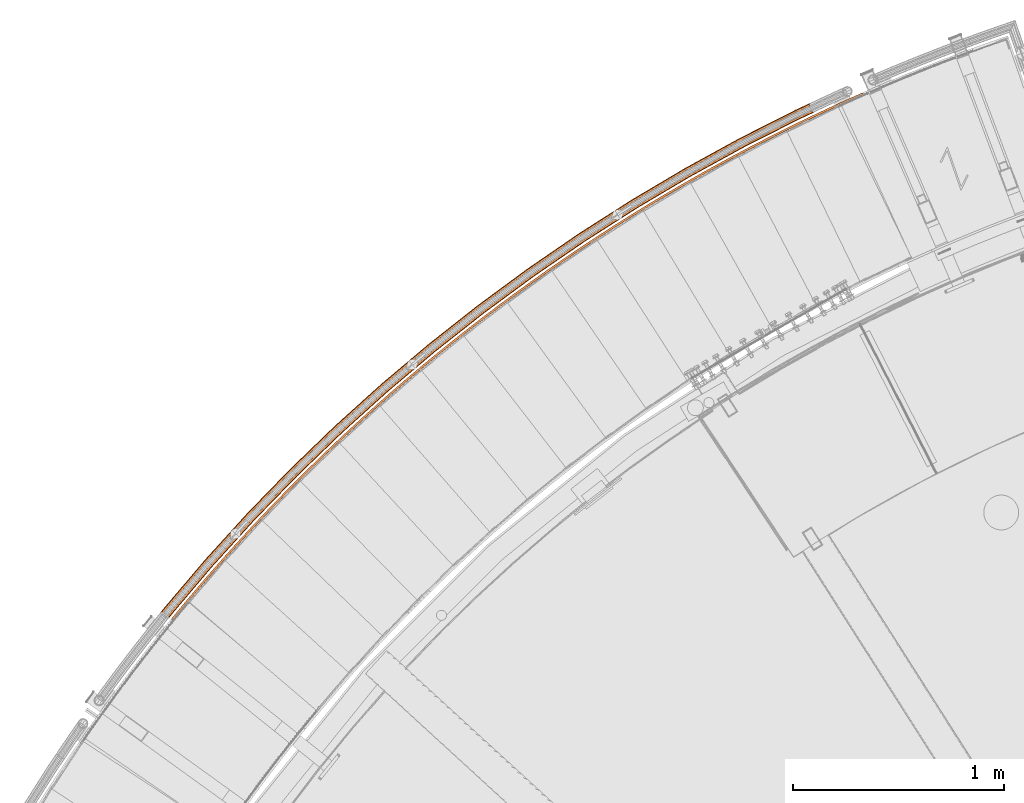
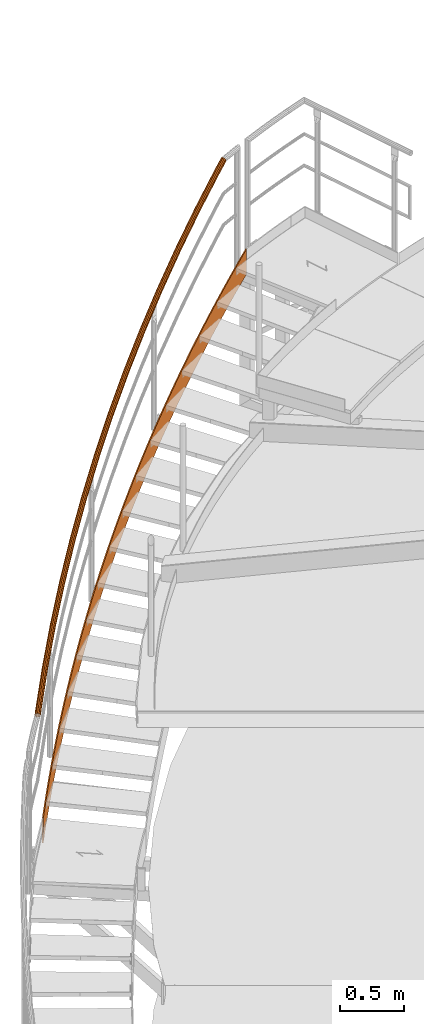
# One storey, part 33 of 126: 2 proxies.
"""IFC2X3 building model written with IfcOpenShell, lengths in millimetres."""

import ifcopenshell
import ifcopenshell.guid

model = None  # the IFC model being written
_history = None  # IfcOwnerHistory: only IFC2X3 demands one
_inside = {}  # id of a spatial element -> (the spatial element, [elements in it])
_under = {}  # id of a project, library or spatial element -> (it, [spatial elements below it])
_declared = {}  # id of a project -> (the project, [libraries it declares])
_typed = {}  # id of a type object -> (the type object, [elements of that type])
_made_of = {}  # id of a material, layer set ... -> (it, [elements and type objects made of it])


def new_model(schema):
    """Start an empty IFC model of exactly this schema.

    Asked for "IFC4X3", IfcOpenShell would pick the latest addendum, in which some entities
    have other attributes; the version numbers below select the first issue.
    IFC2X3 requires an IfcOwnerHistory on every rooted entity: one is made here for all.
    """
    global model, _history
    if schema == "IFC4X3":
        model = ifcopenshell.file(schema_version=(4, 3, 0, 0))
    else:
        model = ifcopenshell.file(schema=schema)
    _inside.clear()
    _under.clear()
    _declared.clear()
    _typed.clear()
    _made_of.clear()
    _history = None
    if model.schema == "IFC2X3":
        org = make("IfcOrganization", Name="unknown")
        user = make(
            "IfcPersonAndOrganization",
            ThePerson=make("IfcPerson", FamilyName="unknown"),
            TheOrganization=org,
        )
        app = make(
            "IfcApplication",
            ApplicationDeveloper=org,
            Version="unknown",
            ApplicationFullName="unknown",
            ApplicationIdentifier="unknown",
        )
        _history = make(
            "IfcOwnerHistory",
            OwningUser=user,
            OwningApplication=app,
            ChangeAction="ADDED",
            CreationDate=0,
        )
    return model


def make(cls, **values):
    """One entity of the class cls with the attributes given. An attribute that is None is left unset."""
    return model.create_entity(
        cls, **{name: value for name, value in values.items() if value is not None}
    )


def rooted(cls, **values):
    """An entity with a GlobalId (a new one), such as an element, a storey or a relation."""
    return make(cls, GlobalId=ifcopenshell.guid.new(), OwnerHistory=_history, **values)


def si_unit(unit_type, name, prefix=None):
    """IfcSIUnit, for example si_unit("LENGTHUNIT", "METRE", prefix="MILLI")."""
    return make("IfcSIUnit", UnitType=unit_type, Prefix=prefix, Name=name)


def assignment(units):
    """IfcUnitAssignment: the units of a project."""
    return None if units is None else make("IfcUnitAssignment", Units=units)


def point(xyz):
    """IfcCartesianPoint."""
    return None if xyz is None else make("IfcCartesianPoint", Coordinates=xyz)


def direction(xyz):
    """IfcDirection."""
    return None if xyz is None else make("IfcDirection", DirectionRatios=xyz)


def frame(location, z_axis=None, x_axis=None):
    """IfcAxis2Placement3D, a coordinate frame: its origin and axes. An axis left out is left unset."""
    return make(
        "IfcAxis2Placement3D",
        Location=point(location),
        Axis=direction(z_axis),
        RefDirection=direction(x_axis),
    )


def origin():
    """The frame at (0, 0, 0) with its axes left unset."""
    return frame((0.0, 0.0, 0.0))


def origin_with_axes():
    """The frame at (0, 0, 0) with the z axis (0, 0, 1) and the x axis (1, 0, 0) written out."""
    return frame((0.0, 0.0, 0.0), z_axis=(0.0, 0.0, 1.0), x_axis=(1.0, 0.0, 0.0))


def place(relative_to, where):
    """IfcLocalPlacement: puts the frame where relative to a parent placement (None: the world)."""
    return make(
        "IfcLocalPlacement", PlacementRelTo=relative_to, RelativePlacement=where
    )


def context(
    kind, dimensions, precision=None, world=None, true_north=None, identifier=None
):
    """IfcGeometricRepresentationContext, for example the 3D "Model" context."""
    return make(
        "IfcGeometricRepresentationContext",
        ContextIdentifier=identifier,
        ContextType=kind,
        CoordinateSpaceDimension=dimensions,
        Precision=precision,
        WorldCoordinateSystem=world,
        TrueNorth=true_north,
    )


def project(units=None, contexts=None):
    """IfcProject with its units and contexts."""
    return rooted(
        "IfcProject",
        Name="project",
        RepresentationContexts=contexts,
        UnitsInContext=assignment(units),
    )


def spatial(cls, under=None, at=None, **own):
    """A site, building, storey or space (cls), placed at a placement, below another one or the project."""
    s = rooted(cls, ObjectPlacement=at, **own)
    if under is not None:
        _under.setdefault(under.id(), (under, []))[1].append(s)
    return s


def faces_of(points, faces, orient=None, outer=None):
    """IfcFace entities. A face is a list of loops; a loop is a list of indices into points, from 0.

    orient and outer hold one flag for each loop. By default every Orientation is true, the
    first loop of a face is its IfcFaceOuterBound and the others are IfcFaceBound.
    """
    made = []
    for i, loops in enumerate(faces):
        bounds = []
        for j, loop in enumerate(loops):
            is_outer = j == 0 if outer is None else outer[i][j]
            bounds.append(
                make(
                    "IfcFaceOuterBound" if is_outer else "IfcFaceBound",
                    Bound=make("IfcPolyLoop", Polygon=[points[k] for k in loop]),
                    Orientation=True if orient is None else orient[i][j],
                )
            )
        made.append(make("IfcFace", Bounds=bounds))
    return made


def faceted_brep(points, faces, orient=None, outer=None, voids=None):
    """IfcFacetedBrep: a solid bounded by flat faces; with voids (closed shells), ...WithVoids."""
    shared = [point(p) for p in points]
    hull = make("IfcClosedShell", CfsFaces=faces_of(shared, faces, orient, outer))
    if voids is None:
        return make("IfcFacetedBrep", Outer=hull)
    return make(
        "IfcFacetedBrepWithVoids",
        Outer=hull,
        Voids=[
            make(cls, CfsFaces=faces_of(shared, fs, o, b)) for cls, fs, o, b in voids
        ],
    )


def shape(context_of_items, identifier, shape_type, items):
    """IfcShapeRepresentation: the items that make up one representation, for example the "Body"."""
    return make(
        "IfcShapeRepresentation",
        ContextOfItems=context_of_items,
        RepresentationIdentifier=identifier,
        RepresentationType=shape_type,
        Items=items,
    )


def material(Name=None, Category=None):
    """IfcMaterial."""
    return make("IfcMaterial", Name=Name, Category=Category)


def made_of(thing, what):
    """Note that an element or type object is made of a material, layer set ...; save() writes the relation."""
    if what is not None:
        _made_of.setdefault(what.id(), (what, []))[1].append(thing)
    return thing


def element(
    cls,
    number,
    at=None,
    inside=None,
    cuts=None,
    type_object=None,
    material=None,
    context=None,
    identifier="Body",
    shape_type=None,
    held_by="IfcProductDefinitionShape",
    body=None,
    shapes=None,
    **own,
):
    """One element of the class cls, such as IfcWall. Its Tag is "e" and its number.

    at: its placement. inside: the storey or other place that contains it. cuts: it is an
    opening in that element (IfcRelVoidsElement). A single representation is given by context,
    identifier, shape_type and body (its items); several are given by shapes. held_by: the class
    of the entity that holds the representations. save() writes the other relations.
    """
    e = rooted(cls, Tag="e%d" % number, ObjectPlacement=at, **own)
    if body is not None:
        shapes = [shape(context, identifier, shape_type, body)]
    if shapes is not None:
        e.Representation = make(held_by, Representations=shapes)
    if inside is not None:
        _inside.setdefault(inside.id(), (inside, []))[1].append(e)
    if cuts is not None:
        rooted(
            "IfcRelVoidsElement", RelatingBuildingElement=cuts, RelatedOpeningElement=e
        )
    if type_object is not None:
        _typed.setdefault(type_object.id(), (type_object, []))[1].append(e)
    return made_of(e, material)


def aggregate(whole, parts):
    """IfcRelAggregates: a whole, such as a stair, and the parts it consists of."""
    return rooted("IfcRelAggregates", RelatingObject=whole, RelatedObjects=parts)


def save(model, path):
    """Write the relations noted so far, then the file.

    IfcRelAggregates (storeys below a building ...), IfcRelContainedInSpatialStructure (elements
    in a storey), IfcRelDefinesByType, IfcRelAssociatesMaterial and IfcRelDeclares: one each for
    every whole, place, type object, material and project.
    """
    for whole, parts in _under.values():
        aggregate(whole, parts)
    for where, things in _inside.values():
        rooted(
            "IfcRelContainedInSpatialStructure",
            RelatedElements=things,
            RelatingStructure=where,
        )
    for kind, things in _typed.values():
        rooted("IfcRelDefinesByType", RelatedObjects=things, RelatingType=kind)
    for what, things in _made_of.values():
        rooted("IfcRelAssociatesMaterial", RelatedObjects=things, RelatingMaterial=what)
    for by, libraries in _declared.values():
        rooted("IfcRelDeclares", RelatingContext=by, RelatedDefinitions=libraries)
    model.write(path)


model = new_model("IFC2X3")

# Units and contexts
context_of_model_1 = context(None, 3, precision=0.1, world=origin())
context_of_model_2 = context(None, 3, precision=0.1, world=origin())
ifc_project = project(units=[si_unit("LENGTHUNIT", "METRE", prefix="MILLI"), si_unit("AREAUNIT", "SQUARE_METRE", prefix="CENTI"), si_unit("VOLUMEUNIT", "CUBIC_METRE", prefix="CENTI"), si_unit("MASSUNIT", "GRAM", prefix="KILO")], contexts=[context_of_model_1, context_of_model_2])

# Site, building, storey
site_placement = place(None, origin_with_axes())
site = spatial("IfcSite", under=ifc_project, at=site_placement, CompositionType="ELEMENT")
building_placement = place(site_placement, origin_with_axes())
building = spatial("IfcBuilding", under=site, at=building_placement, CompositionType="ELEMENT")
storey_placement = place(building_placement, origin_with_axes())
storey = spatial("IfcBuildingStorey", under=building, at=storey_placement, CompositionType="ELEMENT")

# Proxies
ifc_material = material(Name="S235JRG2")
proxy_1_placement = place(storey_placement, origin_with_axes())
element("IfcBuildingElementProxy", 1, at=proxy_1_placement, inside=storey, material=ifc_material, context=context_of_model_2, shape_type="Brep", body=[
    faceted_brep([(1171.975, 13596.155, 8180.5555), (1179.7144, 13589.822, 8180.4818), (1172.9851, 13581.509, 8173.3481), (1164.7173, 13587.189, 8172.8657), (1179.7144, 13589.822, 8420.8856), (1172.9851, 13581.509, 8413.7497), (1171.975, 13596.155, 8420.9209), (1164.7173, 13587.189, 8413.2335), (1231.5673, 13668.201, 8242.8751), (1239.2392, 13661.787, 8242.7807), (1239.2392, 13661.787, 8483.1948), (1231.5673, 13668.201, 8483.2301), (1291.9192, 13739.613, 8305.19), (1299.5227, 13733.118, 8305.0843), (1299.5227, 13733.118, 8545.5041), (1291.9192, 13739.613, 8545.5394), (1353.0239, 13810.382, 8367.5023), (1360.5583, 13803.806, 8367.3904), (1360.5583, 13803.806, 8607.8133), (1353.0239, 13810.382, 8607.8486), (1414.8746, 13880.499, 8429.8132), (1422.3389, 13873.844, 8429.698), (1422.3389, 13873.844, 8670.1226), (1414.8746, 13880.499, 8670.1579), (1477.4644, 13949.958, 8492.1234), (1484.8578, 13943.224, 8492.0064), (1484.8578, 13943.224, 8732.4318), (1477.4644, 13949.958, 8732.4671), (1540.7863, 14018.749, 8554.4331), (1548.1079, 14011.938, 8554.3151), (1548.1079, 14011.938, 8794.7411), (1540.7863, 14018.749, 8794.7764), (1604.833, 14086.867, 8616.7426), (1612.0822, 14079.978, 8616.6241), (1612.0822, 14079.978, 8857.0503), (1604.833, 14086.867, 8857.0856), (1669.5976, 14154.302, 8679.052), (1676.7733, 14147.337, 8678.9332), (1676.7733, 14147.337, 8919.3596), (1669.5976, 14154.302, 8919.3949), (1735.0726, 14221.048, 8741.3613), (1742.1742, 14214.007, 8741.2424), (1742.1742, 14214.007, 8981.6688), (1735.0726, 14221.048, 8981.7041), (1801.2508, 14287.097, 8803.6706), (1808.2774, 14279.981, 8803.5516), (1808.2774, 14279.981, 9043.9781), (1801.2508, 14287.097, 9044.0134), (1868.1247, 14352.441, 8865.9799), (1875.0756, 14345.251, 8865.8608), (1875.0756, 14345.251, 9106.2873), (1868.1247, 14352.441, 9106.3226), (1935.6868, 14417.073, 8928.2892), (1942.5612, 14409.81, 8928.17), (1942.5612, 14409.81, 9168.5966), (1935.6868, 14417.073, 9168.6319), (2003.9296, 14480.986, 8990.5984), (2010.7267, 14473.651, 8990.4793), (2010.7267, 14473.651, 9230.9058), (2003.9296, 14480.986, 9230.9411), (2072.8454, 14544.173, 9052.9077), (2079.5644, 14536.766, 9052.7885), (2079.5644, 14536.766, 9293.215), (2072.8454, 14544.173, 9293.2504), (2142.4264, 14606.626, 9115.2169), (2149.0666, 14599.149, 9115.0978), (2149.0666, 14599.149, 9355.5243), (2142.4264, 14606.626, 9355.5596), (2212.6649, 14668.34, 9177.5262), (2219.2256, 14660.792, 9177.407), (2219.2256, 14660.792, 9417.8335), (2212.6649, 14668.34, 9417.8688), (2283.5531, 14729.306, 9239.8354), (2290.0334, 14721.689, 9239.7163), (2290.0334, 14721.689, 9480.1428), (2283.5531, 14729.306, 9480.1781), (2355.0828, 14789.517, 9302.1447), (2361.4822, 14781.833, 9302.0255), (2361.4822, 14781.833, 9542.452), (2355.0828, 14789.517, 9542.4873), (2427.2462, 14848.968, 9364.4539), (2433.5638, 14841.217, 9364.3347), (2433.5638, 14841.217, 9604.7613), (2427.2462, 14848.968, 9604.7966), (2500.0351, 14907.652, 9426.7631), (2506.2703, 14899.834, 9426.644), (2506.2703, 14899.834, 9667.0705), (2500.0351, 14907.652, 9667.1058), (2573.4413, 14965.561, 9489.0724), (2579.5934, 14957.677, 9488.9532), (2579.5934, 14957.677, 9729.3798), (2573.4413, 14965.561, 9729.4151), (2647.4567, 15022.69, 9551.3816), (2653.5249, 15014.741, 9551.2625), (2653.5249, 15014.741, 9791.689), (2647.4567, 15022.69, 9791.7243), (2722.0729, 15079.031, 9613.6909), (2728.0566, 15071.019, 9613.5717), (2728.0566, 15071.019, 9853.9983), (2722.0729, 15079.031, 9854.0336), (2797.2816, 15134.58, 9676.0001), (2803.1801, 15126.505, 9675.881), (2803.1801, 15126.505, 9916.3075), (2797.2816, 15134.58, 9916.3428), (2873.0743, 15189.329, 9738.3094), (2878.887, 15181.191, 9738.1902), (2878.887, 15181.191, 9978.6168), (2873.0743, 15189.329, 9978.6521), (2949.4426, 15243.272, 9800.6186), (2955.1687, 15235.073, 9800.4995), (2955.1687, 15235.073, 10040.926), (2949.4426, 15243.272, 10040.961), (3026.3778, 15296.403, 9862.9279), (3032.0168, 15288.145, 9862.8087), (3032.0168, 15288.145, 10103.235), (3026.3778, 15296.403, 10103.271), (3103.8713, 15348.717, 9925.2371), (3109.4226, 15340.399, 9925.118), (3109.4226, 15340.399, 10165.545), (3103.8713, 15348.717, 10165.58), (3181.9145, 15400.207, 9987.5464), (3187.3774, 15391.831, 9987.4272), (3187.3774, 15391.831, 10227.854), (3181.9145, 15400.207, 10227.889), (3260.4986, 15450.868, 10049.856), (3265.8724, 15442.434, 10049.737), (3265.8724, 15442.434, 10290.163), (3260.4986, 15450.868, 10290.198), (3339.6147, 15500.693, 10112.165), (3344.899, 15492.204, 10112.046), (3344.899, 15492.204, 10352.472), (3339.6147, 15500.693, 10352.508), (3419.2541, 15549.679, 10174.474), (3424.4481, 15541.133, 10174.355), (3424.4481, 15541.133, 10414.781), (3419.2541, 15549.679, 10414.817), (3499.4077, 15597.818, 10236.783), (3504.511, 15589.218, 10236.664), (3504.511, 15589.218, 10477.091), (3499.4077, 15597.818, 10477.126), (3580.0666, 15645.105, 10299.093), (3585.0785, 15636.451, 10298.974), (3585.0785, 15636.451, 10539.4), (3580.0666, 15645.105, 10539.435), (3661.2218, 15691.536, 10361.402), (3666.1418, 15682.83, 10361.283), (3666.1418, 15682.83, 10601.709), (3661.2218, 15691.536, 10601.745), (3742.8641, 15737.104, 10423.711), (3747.6916, 15728.347, 10423.592), (3747.6916, 15728.347, 10664.019), (3742.8641, 15737.104, 10664.054), (3824.9844, 15781.806, 10486.02), (3829.7189, 15772.998, 10485.901), (3829.7189, 15772.998, 10726.328), (3824.9844, 15781.806, 10726.363), (3907.5735, 15825.635, 10548.33), (3912.2144, 15816.777, 10548.21), (3912.2144, 15816.777, 10788.637), (3907.5735, 15825.635, 10788.672), (3990.622, 15868.588, 10610.639), (3995.1689, 15859.681, 10610.52), (3995.1689, 15859.681, 10850.946), (3990.622, 15868.588, 10850.982), (4074.1208, 15910.658, 10672.948), (4078.5731, 15901.704, 10672.829), (4078.5731, 15901.704, 10913.255), (4074.1208, 15910.658, 10913.291), (4158.0604, 15951.842, 10735.257), (4162.4177, 15942.841, 10735.138), (4162.4177, 15942.841, 10975.565), (4158.0604, 15951.842, 10975.6), (4242.4315, 15992.135, 10797.567), (4246.6931, 15983.088, 10797.447), (4246.6931, 15983.088, 11037.874), (4242.4315, 15992.135, 11037.909), (4327.2244, 16031.532, 10859.876), (4331.3901, 16022.44, 10859.757), (4331.3901, 16022.44, 11100.183), (4327.2244, 16031.532, 11100.219), (4412.4299, 16070.028, 10922.185), (4416.499, 16060.894, 10922.066), (4416.499, 16060.894, 11162.493), (4412.4299, 16070.028, 11162.528), (4443.6484, 16083.737, 10944.907), (4447.8285, 16074.651, 10944.895), (4447.8285, 16074.651, 11185.321), (4443.6484, 16083.737, 11185.25)], [[[0, 1, 2, 3]], [[1, 4, 5, 2]], [[4, 6, 7, 5]], [[0, 3, 7, 6]], [[0, 8, 9, 1]], [[1, 9, 10, 4]], [[4, 10, 11, 6]], [[6, 11, 8, 0]], [[8, 12, 13, 9]], [[9, 13, 14, 10]], [[10, 14, 15, 11]], [[11, 15, 12, 8]], [[12, 16, 17, 13]], [[13, 17, 18, 14]], [[14, 18, 19, 15]], [[15, 19, 16, 12]], [[16, 20, 21, 17]], [[17, 21, 22, 18]], [[18, 22, 23, 19]], [[19, 23, 20, 16]], [[20, 24, 25, 21]], [[21, 25, 26, 22]], [[22, 26, 27, 23]], [[23, 27, 24, 20]], [[24, 28, 29, 25]], [[25, 29, 30, 26]], [[26, 30, 31, 27]], [[27, 31, 28, 24]], [[28, 32, 33, 29]], [[29, 33, 34, 30]], [[30, 34, 35, 31]], [[31, 35, 32, 28]], [[32, 36, 37, 33]], [[33, 37, 38, 34]], [[34, 38, 39, 35]], [[35, 39, 36, 32]], [[36, 40, 41, 37]], [[37, 41, 42, 38]], [[38, 42, 43, 39]], [[39, 43, 40, 36]], [[40, 44, 45, 41]], [[41, 45, 46, 42]], [[42, 46, 47, 43]], [[43, 47, 44, 40]], [[44, 48, 49, 45]], [[45, 49, 50, 46]], [[46, 50, 51, 47]], [[47, 51, 48, 44]], [[48, 52, 53, 49]], [[49, 53, 54, 50]], [[50, 54, 55, 51]], [[51, 55, 52, 48]], [[52, 56, 57, 53]], [[53, 57, 58, 54]], [[54, 58, 59, 55]], [[55, 59, 56, 52]], [[56, 60, 61, 57]], [[57, 61, 62, 58]], [[58, 62, 63, 59]], [[59, 63, 60, 56]], [[60, 64, 65, 61]], [[61, 65, 66, 62]], [[62, 66, 67, 63]], [[63, 67, 64, 60]], [[64, 68, 69, 65]], [[65, 69, 70, 66]], [[66, 70, 71, 67]], [[67, 71, 68, 64]], [[68, 72, 73, 69]], [[69, 73, 74, 70]], [[70, 74, 75, 71]], [[71, 75, 72, 68]], [[72, 76, 77, 73]], [[73, 77, 78, 74]], [[74, 78, 79, 75]], [[75, 79, 76, 72]], [[76, 80, 81, 77]], [[77, 81, 82, 78]], [[78, 82, 83, 79]], [[79, 83, 80, 76]], [[80, 84, 85, 81]], [[81, 85, 86, 82]], [[82, 86, 87, 83]], [[83, 87, 84, 80]], [[84, 88, 89, 85]], [[85, 89, 90, 86]], [[86, 90, 91, 87]], [[87, 91, 88, 84]], [[88, 92, 93, 89]], [[89, 93, 94, 90]], [[90, 94, 95, 91]], [[91, 95, 92, 88]], [[92, 96, 97, 93]], [[93, 97, 98, 94]], [[94, 98, 99, 95]], [[95, 99, 96, 92]], [[96, 100, 101, 97]], [[97, 101, 102, 98]], [[98, 102, 103, 99]], [[99, 103, 100, 96]], [[100, 104, 105, 101]], [[101, 105, 106, 102]], [[102, 106, 107, 103]], [[103, 107, 104, 100]], [[104, 108, 109, 105]], [[105, 109, 110, 106]], [[106, 110, 111, 107]], [[107, 111, 108, 104]], [[108, 112, 113, 109]], [[109, 113, 114, 110]], [[110, 114, 115, 111]], [[111, 115, 112, 108]], [[112, 116, 117, 113]], [[113, 117, 118, 114]], [[114, 118, 119, 115]], [[115, 119, 116, 112]], [[116, 120, 121, 117]], [[117, 121, 122, 118]], [[118, 122, 123, 119]], [[119, 123, 120, 116]], [[120, 124, 125, 121]], [[121, 125, 126, 122]], [[122, 126, 127, 123]], [[123, 127, 124, 120]], [[124, 128, 129, 125]], [[125, 129, 130, 126]], [[126, 130, 131, 127]], [[127, 131, 128, 124]], [[128, 132, 133, 129]], [[129, 133, 134, 130]], [[130, 134, 135, 131]], [[131, 135, 132, 128]], [[132, 136, 137, 133]], [[133, 137, 138, 134]], [[134, 138, 139, 135]], [[135, 139, 136, 132]], [[136, 140, 141, 137]], [[137, 141, 142, 138]], [[138, 142, 143, 139]], [[139, 143, 140, 136]], [[140, 144, 145, 141]], [[141, 145, 146, 142]], [[142, 146, 147, 143]], [[143, 147, 144, 140]], [[144, 148, 149, 145]], [[145, 149, 150, 146]], [[146, 150, 151, 147]], [[147, 151, 148, 144]], [[148, 152, 153, 149]], [[149, 153, 154, 150]], [[150, 154, 155, 151]], [[151, 155, 152, 148]], [[152, 156, 157, 153]], [[153, 157, 158, 154]], [[154, 158, 159, 155]], [[155, 159, 156, 152]], [[156, 160, 161, 157]], [[157, 161, 162, 158]], [[158, 162, 163, 159]], [[159, 163, 160, 156]], [[160, 164, 165, 161]], [[161, 165, 166, 162]], [[162, 166, 167, 163]], [[163, 167, 164, 160]], [[164, 168, 169, 165]], [[165, 169, 170, 166]], [[166, 170, 171, 167]], [[167, 171, 168, 164]], [[168, 172, 173, 169]], [[169, 173, 174, 170]], [[170, 174, 175, 171]], [[171, 175, 172, 168]], [[172, 176, 177, 173]], [[173, 177, 178, 174]], [[174, 178, 179, 175]], [[175, 179, 176, 172]], [[176, 180, 181, 177]], [[177, 181, 182, 178]], [[178, 182, 183, 179]], [[179, 183, 180, 176]], [[180, 184, 185, 181]], [[181, 185, 186, 182]], [[182, 186, 187, 183]], [[180, 183, 187, 184]], [[2, 5, 7, 3]], [[184, 187, 186, 185]]]),
])
proxy_2_placement = place(storey_placement, origin_with_axes())
element("IfcBuildingElementProxy", 2, at=proxy_2_placement, inside=storey, material=ifc_material, Name="HANDLAUF", context=context_of_model_2, shape_type="Brep", body=[
    faceted_brep([(1143.6126, 13616.761, 9429.2389), (1135.3792, 13625.817, 9426.689), (1120.7453, 13607.305, 9410.0572), (1129.9924, 13599.531, 9413.7592), (1131.6642, 13635.371, 9419.5336), (1115.248, 13614.604, 9400.8762), (1133.463, 13642.864, 9409.6899), (1114.9735, 13619.475, 9388.6762), (1140.2937, 13646.288, 9399.7956), (1119.9954, 13620.61, 9376.7262), (1150.3259, 13644.725, 9392.5018), (1128.9681, 13617.707, 9368.2282), (1160.8716, 13638.594, 9389.763), (1139.4873, 13611.542, 9365.4592), (1169.105, 13629.538, 9392.3128), (1148.7344, 13603.769, 9369.1612), (1172.82, 13619.983, 9399.4683), (1154.2317, 13596.469, 9378.3422), (1171.0212, 13612.49, 9409.3119), (1154.5061, 13591.599, 9390.5422), (1164.1905, 13609.067, 9419.2062), (1149.4842, 13590.463, 9402.4922), (1154.1583, 13610.63, 9426.5), (1140.5116, 13593.367, 9410.9902), (1144.506, 13617.891, 9427.1956), (1153.9599, 13612.395, 9424.7403), (1139.9141, 13594.627, 9408.7769), (1130.4838, 13600.153, 9411.2592), (1162.9536, 13610.993, 9418.2015), (1147.9579, 13592.024, 9401.1586), (1169.0772, 13614.063, 9409.3315), (1152.4599, 13593.041, 9390.4456), (1170.6898, 13620.78, 9400.5068), (1152.2139, 13597.407, 9379.5086), (1167.3594, 13629.345, 9394.0922), (1147.2857, 13603.952, 9371.278), (1159.9783, 13637.464, 9391.8062), (1138.9958, 13610.921, 9367.9592), (1150.5243, 13642.96, 9394.2616), (1129.5655, 13616.447, 9370.4415), (1141.5306, 13644.361, 9400.8003), (1121.5217, 13619.05, 9378.0598), (1135.407, 13641.292, 9409.6704), (1117.0197, 13618.032, 9388.7727), (1133.7944, 13634.575, 9418.495), (1117.2657, 13613.666, 9399.7098), (1137.1249, 13626.009, 9424.9097), (1122.194, 13607.122, 9407.9404), (1333.8964, 13841.683, 9636.8856), (1325.9685, 13851.008, 9634.3357), (1322.5733, 13860.681, 9627.1801), (1324.6203, 13868.109, 9617.3363), (1331.5611, 13871.304, 9607.4421), (1341.5356, 13869.408, 9600.1485), (1351.8714, 13862.93, 9597.4097), (1359.799, 13853.606, 9599.9595), (1363.1944, 13843.934, 9607.1148), (1361.1477, 13836.505, 9616.9583), (1354.2072, 13833.31, 9626.8527), (1344.2325, 13835.205, 9634.1467), (1334.8267, 13842.783, 9634.8424), (1344.0929, 13836.976, 9632.3869), (1353.035, 13835.277, 9625.8481), (1359.257, 13838.141, 9616.978), (1361.0919, 13844.8, 9608.1534), (1358.048, 13853.472, 9601.7388), (1350.941, 13861.831, 9599.453), (1341.6752, 13867.638, 9601.9083), (1332.7332, 13869.337, 9608.4468), (1326.511, 13866.473, 9617.3168), (1324.6758, 13859.814, 9626.1415), (1327.7196, 13851.142, 9632.5564), (1531.5498, 14060.158, 9844.5324), (1523.9362, 14069.741, 9841.9824), (1520.8643, 14079.521, 9834.8268), (1523.1571, 14086.878, 9824.9831), (1530.2001, 14089.84, 9815.0888), (1540.1062, 14087.614, 9807.7952), (1550.221, 14080.796, 9805.0565), (1557.8344, 14071.213, 9807.6063), (1560.9064, 14061.433, 9814.7615), (1558.614, 14054.077, 9824.6051), (1551.5711, 14051.114, 9834.4995), (1541.6649, 14053.34, 9841.7934), (1532.5162, 14061.226, 9842.4891), (1541.5842, 14055.114, 9840.0337), (1550.4649, 14053.119, 9833.4948), (1556.7787, 14055.774, 9824.6247), (1558.8339, 14062.37, 9815.8001), (1556.0798, 14071.137, 9809.3856), (1549.2545, 14079.728, 9807.0997), (1540.1868, 14085.84, 9809.555), (1531.3062, 14087.835, 9816.0936), (1524.9923, 14085.18, 9824.9636), (1522.9368, 14078.585, 9833.7883), (1525.6908, 14069.817, 9840.2031), (1736.3545, 14271.943, 10052.179), (1729.0636, 14281.774, 10049.629), (1726.3183, 14291.651, 10042.474), (1728.8544, 14298.927, 10032.63), (1735.992, 14301.654, 10022.736), (1745.8186, 14299.1, 10015.442), (1755.7012, 14291.949, 10012.703), (1762.9919, 14282.119, 10015.253), (1765.7373, 14272.243, 10022.408), (1763.2016, 14264.966, 10032.252), (1756.0642, 14262.239, 10042.146), (1746.2374, 14264.793, 10049.44), (1737.3559, 14272.979, 10050.136), (1746.2157, 14266.569, 10047.68), (1755.0252, 14264.279, 10041.142), (1761.4238, 14266.724, 10032.272), (1763.697, 14273.247, 10023.447), (1761.2358, 14282.101, 10017.032), (1754.6998, 14290.914, 10014.746), (1745.8402, 14297.324, 10017.202), (1737.0309, 14299.613, 10023.74), (1730.6321, 14297.169, 10032.61), (1728.3587, 14290.646, 10041.435), (1730.8197, 14281.792, 10047.85), (1948.0842, 14476.805, 10259.826), (1941.124, 14486.873, 10257.276), (1938.7086, 14496.835, 10250.12), (1941.485, 14504.024, 10240.277), (1948.7093, 14506.511, 10230.382), (1958.4456, 14503.632, 10223.089), (1968.0852, 14496.158, 10220.35), (1975.0452, 14486.09, 10222.9), (1977.4608, 14476.128, 10230.055), (1974.6847, 14468.94, 10239.899), (1967.4606, 14466.452, 10249.793), (1957.7241, 14469.331, 10257.087), (1949.1195, 14477.807, 10257.783), (1957.7614, 14471.106, 10255.327), (1966.49, 14468.525, 10248.788), (1972.9663, 14470.756, 10239.918), (1975.455, 14477.2, 10231.094), (1973.2894, 14486.131, 10224.679), (1967.0499, 14495.156, 10222.393), (1958.4082, 14501.857, 10224.849), (1949.6798, 14504.438, 10231.387), (1943.2034, 14502.208, 10240.257), (1940.7144, 14495.764, 10249.082), (1942.8798, 14486.832, 10255.497), (2166.5052, 14674.518, 10467.473), (2159.8834, 14684.811, 10464.923), (2157.8004, 14694.849, 10457.767), (2160.8141, 14701.941, 10447.923), (2168.1171, 14704.187, 10438.029), (2177.7523, 14700.986, 10430.736), (2187.1382, 14693.195, 10427.997), (2193.7598, 14682.902, 10430.547), (2195.843, 14672.865, 10437.702), (2192.8295, 14665.773, 10447.545), (2185.5267, 14663.526, 10457.44), (2175.8913, 14666.727, 10464.734), (2167.5731, 14675.485, 10465.429), (2175.9876, 14668.5, 10462.974), (2184.6256, 14665.631, 10456.435), (2191.1724, 14667.645, 10447.565), (2193.8739, 14674.003, 10438.74), (2192.0064, 14683.001, 10432.326), (2186.0702, 14692.228, 10430.04), (2177.656, 14699.213, 10432.495), (2169.0182, 14702.082, 10439.034), (2162.4712, 14700.068, 10447.904), (2159.7694, 14693.711, 10456.728), (2161.6368, 14684.713, 10463.143), (2391.376, 14864.863, 10675.119), (2385.0999, 14875.371, 10672.569), (2383.3516, 14885.472, 10665.414), (2386.5994, 14892.459, 10655.57), (2393.973, 14894.462, 10645.676), (2403.4965, 14890.942, 10638.382), (2412.6182, 14882.844, 10635.643), (2418.8942, 14872.336, 10638.193), (2420.6427, 14862.236, 10645.349), (2417.3952, 14855.248, 10655.192), (2410.0218, 14853.245, 10665.086), (2400.498, 14856.764, 10672.38), (2392.4755, 14865.794, 10673.076), (2400.6532, 14858.533, 10670.621), (2409.191, 14855.378, 10664.082), (2415.8012, 14857.174, 10655.212), (2418.7125, 14863.438, 10646.387), (2417.145, 14872.493, 10639.973), (2411.5188, 14881.913, 10637.687), (2403.3413, 14889.173, 10640.142), (2394.8036, 14892.328, 10646.681), (2388.1934, 14890.533, 10655.55), (2385.2818, 14884.269, 10664.375), (2386.8491, 14875.213, 10670.79), (2622.4482, 15047.629, 10882.766), (2616.5249, 15058.34, 10880.216), (2615.1132, 15068.493, 10873.061), (2618.5914, 15075.369, 10863.217), (2626.0274, 15077.126, 10853.323), (2635.4287, 15073.291, 10846.029), (2644.2763, 15064.894, 10843.29), (2650.1996, 15054.184, 10845.84), (2651.6114, 15044.031, 10852.995), (2648.1335, 15037.155, 10862.839), (2640.6976, 15035.398, 10872.733), (2631.2961, 15039.232, 10880.027), (2623.5781, 15048.523, 10880.723), (2631.51, 15040.995, 10878.267), (2639.9382, 15037.558, 10871.729), (2646.6044, 15039.133, 10862.858), (2649.7223, 15045.297, 10854.034), (2648.4566, 15054.399, 10847.619), (2643.1465, 15064.001, 10845.334), (2635.2148, 15071.529, 10847.789), (2626.7867, 15074.966, 10854.327), (2620.1205, 15073.391, 10863.197), (2617.0023, 15067.227, 10872.022), (2618.2679, 15058.125, 10878.437), (2859.4667, 15222.616, 11090.413), (2853.9025, 15233.517, 11087.863), (2852.829, 15243.712, 11080.707), (2856.5339, 15250.469, 11070.863), (2864.0241, 15251.977, 11060.969), (2873.2928, 15247.832, 11053.676), (2881.8565, 15239.146, 11050.937), (2887.4205, 15228.245, 11053.487), (2888.4942, 15218.05, 11060.642), (2884.7897, 15211.294, 11070.486), (2877.2995, 15209.785, 11080.38), (2868.0306, 15213.929, 11087.674), (2860.6256, 15223.472, 11088.37), (2868.303, 15215.684, 11085.914), (2876.6123, 15211.969, 11079.375), (2883.3271, 15213.321, 11070.505), (2886.6481, 15219.379, 11061.681), (2885.6856, 15228.518, 11055.266), (2880.6976, 15238.29, 11052.98), (2873.0204, 15246.078, 11055.436), (2864.7112, 15249.793, 11061.974), (2857.9963, 15248.441, 11070.844), (2854.675, 15242.384, 11079.669), (2855.6374, 15233.244, 11086.084), (3102.1695, 15389.629, 11298.06), (3096.9706, 15400.709, 11295.51), (3096.2366, 15410.934, 11288.354), (3100.1639, 15417.564, 11278.51), (3107.7001, 15418.822, 11268.616), (3116.826, 15414.372, 11261.323), (3125.0962, 15405.406, 11258.584), (3130.2949, 15394.326, 11261.134), (3131.0292, 15384.101, 11268.289), (3127.1022, 15377.471, 11278.132), (3119.566, 15376.213, 11288.027), (3110.44, 15380.663, 11295.321), (3103.3561, 15390.446, 11296.016), (3110.7705, 15382.407, 11293.561), (3118.9518, 15378.418, 11287.022), (3125.7078, 15379.546, 11278.152), (3129.2283, 15385.49, 11269.327), (3128.5701, 15394.656, 11262.913), (3123.9095, 15404.589, 11260.627), (3116.4954, 15412.627, 11263.082), (3108.3143, 15416.617, 11269.621), (3101.5582, 15415.489, 11278.491), (3098.0374, 15409.545, 11287.316), (3098.6955, 15400.379, 11293.73), (3350.2885, 15548.484, 11505.706), (3345.4607, 15559.731, 11503.156), (3345.0669, 15569.975, 11496.001), (3349.2124, 15576.47, 11486.157), (3356.7863, 15577.478, 11476.263), (3365.7592, 15572.727, 11468.969), (3373.7269, 15563.49, 11466.23), (3378.5545, 15552.244, 11468.78), (3378.9486, 15542.0, 11475.936), (3374.8034, 15535.505, 11485.779), (3367.2296, 15534.497, 11495.673), (3358.2565, 15539.248, 11502.967), (3351.5016, 15549.261, 11503.663), (3358.6448, 15540.981, 11501.208), (3366.689, 15536.722, 11494.669), (3373.4788, 15537.625, 11485.799), (3377.1948, 15543.448, 11476.974), (3376.8416, 15552.631, 11470.56), (3372.5137, 15562.714, 11468.274), (3365.3708, 15570.994, 11470.729), (3357.3268, 15575.253, 11477.268), (3350.5369, 15574.35, 11486.138), (3346.8206, 15568.527, 11494.962), (3347.1737, 15559.344, 11501.377), (3603.5496, 15699.006, 11713.353), (3599.0983, 15710.407, 11710.803), (3599.0451, 15720.658, 11703.647), (3603.4041, 15727.012, 11693.804), (3611.0073, 15727.767, 11683.91), (3619.8174, 15722.721, 11676.616), (3627.4738, 15713.225, 11673.877), (3631.925, 15701.824, 11676.427), (3631.9784, 15691.573, 11683.582), (3627.6196, 15685.219, 11693.426), (3620.0165, 15684.464, 11703.32), (3611.2062, 15689.51, 11710.614), (3604.7879, 15699.742, 11711.31), (3611.6519, 15691.229, 11708.854), (3619.5502, 15686.705, 11702.316), (3626.3662, 15687.382, 11693.445), (3630.2738, 15693.079, 11684.621), (3630.2259, 15702.269, 11678.206), (3626.2354, 15712.489, 11675.92), (3619.3717, 15721.002, 11678.376), (3611.4736, 15725.526, 11684.914), (3604.6575, 15724.849, 11693.784), (3600.7497, 15719.153, 11702.609), (3600.7974, 15709.963, 11709.024), (3861.6731, 15841.028, 11921.0), (3857.6031, 15852.571, 11918.45), (3857.8906, 15862.818, 11911.294), (3862.4584, 15869.024, 11901.451), (3870.0825, 15869.526, 11891.556), (3878.72, 15864.189, 11884.263), (3886.0566, 15854.444, 11881.524), (3890.1264, 15842.902, 11884.074), (3889.8392, 15832.655, 11891.229), (3885.2716, 15826.449, 11901.073), (3877.6476, 15825.947, 11910.967), (3869.0099, 15831.283, 11918.261), (3862.9352, 15841.723, 11918.957), (3869.5125, 15832.986, 11916.501), (3877.256, 15828.202, 11909.962), (3884.0908, 15828.652, 11901.092), (3888.1855, 15834.216, 11892.268), (3888.443, 15843.402, 11885.853), (3884.7945, 15853.75, 11883.567), (3878.2174, 15862.486, 11886.022), (3870.474, 15867.27, 11892.561), (3863.6392, 15866.82, 11901.431), (3859.5443, 15861.257, 11910.256), (3859.2866, 15852.07, 11916.671), (4124.3738, 15974.394, 12128.647), (4120.6897, 15986.065, 12126.097), (4121.3175, 15996.297, 12118.941), (4126.0891, 16002.348, 12109.097), (4133.7256, 16002.596, 12099.203), (4142.181, 15996.975, 12091.91), (4149.1896, 15986.992, 12089.171), (4152.8737, 15975.321, 12091.72), (4152.246, 15965.089, 12098.876), (4147.4748, 15959.038, 12108.719), (4139.8383, 15958.789, 12118.614), (4131.3827, 15964.41, 12125.908), (4125.6582, 15975.046, 12126.603), (4131.9416, 15966.096, 12124.148), (4139.5218, 15961.057, 12117.609), (4146.3678, 15961.28, 12108.739), (4150.6452, 15966.704, 12099.914), (4151.2078, 15975.877, 12093.5), (4147.9052, 15986.34, 12091.214), (4141.622, 15995.29, 12093.669), (4134.042, 16000.329, 12100.208), (4127.1959, 16000.106, 12109.078), (4122.9184, 15994.682, 12117.903), (4122.3555, 15985.509, 12124.317), (4197.141, 16008.343, 12185.241), (4193.0844, 16019.823, 12182.319), (4191.9325, 16029.176, 12173.711), (4193.9926, 16033.9, 12161.726), (4198.7124, 16032.731, 12149.57), (4204.8288, 16025.981, 12140.498), (4210.7046, 16015.457, 12136.941), (4214.7653, 16003.975, 12139.853), (4215.9216, 15994.613, 12148.459), (4213.8618, 15989.882, 12160.452), (4209.1379, 15991.053, 12172.617), (4203.0171, 15997.812, 12181.691), (4197.8439, 16008.709, 12182.741), (4203.1116, 15999.269, 12179.558), (4208.5986, 15993.21, 12171.424), (4212.8333, 15992.161, 12160.519), (4214.6799, 15996.401, 12149.767), (4213.6435, 16004.793, 12142.052), (4210.0033, 16015.087, 12139.441), (4204.7358, 16024.522, 12142.63), (4199.2524, 16030.573, 12150.762), (4195.021, 16031.621, 12161.66), (4193.1742, 16027.386, 12172.405), (4194.207, 16019.001, 12180.122)], [[[0, 1, 2, 3]], [[1, 4, 5, 2]], [[4, 6, 7, 5]], [[6, 8, 9, 7]], [[8, 10, 11, 9]], [[10, 12, 13, 11]], [[12, 14, 15, 13]], [[14, 16, 17, 15]], [[16, 18, 19, 17]], [[18, 20, 21, 19]], [[20, 22, 23, 21]], [[0, 3, 23, 22]], [[24, 25, 26, 27]], [[25, 28, 29, 26]], [[28, 30, 31, 29]], [[30, 32, 33, 31]], [[32, 34, 35, 33]], [[34, 36, 37, 35]], [[36, 38, 39, 37]], [[38, 40, 41, 39]], [[40, 42, 43, 41]], [[42, 44, 45, 43]], [[44, 46, 47, 45]], [[24, 27, 47, 46]], [[0, 48, 49, 1]], [[1, 49, 50, 4]], [[4, 50, 51, 6]], [[6, 51, 52, 8]], [[8, 52, 53, 10]], [[10, 53, 54, 12]], [[12, 54, 55, 14]], [[14, 55, 56, 16]], [[16, 56, 57, 18]], [[18, 57, 58, 20]], [[20, 58, 59, 22]], [[22, 59, 48, 0]], [[24, 60, 61, 25]], [[25, 61, 62, 28]], [[28, 62, 63, 30]], [[30, 63, 64, 32]], [[32, 64, 65, 34]], [[34, 65, 66, 36]], [[36, 66, 67, 38]], [[38, 67, 68, 40]], [[40, 68, 69, 42]], [[42, 69, 70, 44]], [[44, 70, 71, 46]], [[46, 71, 60, 24]], [[48, 72, 73, 49]], [[49, 73, 74, 50]], [[50, 74, 75, 51]], [[51, 75, 76, 52]], [[52, 76, 77, 53]], [[53, 77, 78, 54]], [[54, 78, 79, 55]], [[55, 79, 80, 56]], [[56, 80, 81, 57]], [[57, 81, 82, 58]], [[58, 82, 83, 59]], [[59, 83, 72, 48]], [[60, 84, 85, 61]], [[61, 85, 86, 62]], [[62, 86, 87, 63]], [[63, 87, 88, 64]], [[64, 88, 89, 65]], [[65, 89, 90, 66]], [[66, 90, 91, 67]], [[67, 91, 92, 68]], [[68, 92, 93, 69]], [[69, 93, 94, 70]], [[70, 94, 95, 71]], [[71, 95, 84, 60]], [[72, 96, 97, 73]], [[73, 97, 98, 74]], [[74, 98, 99, 75]], [[75, 99, 100, 76]], [[76, 100, 101, 77]], [[77, 101, 102, 78]], [[78, 102, 103, 79]], [[79, 103, 104, 80]], [[80, 104, 105, 81]], [[81, 105, 106, 82]], [[82, 106, 107, 83]], [[83, 107, 96, 72]], [[84, 108, 109, 85]], [[85, 109, 110, 86]], [[86, 110, 111, 87]], [[87, 111, 112, 88]], [[88, 112, 113, 89]], [[89, 113, 114, 90]], [[90, 114, 115, 91]], [[91, 115, 116, 92]], [[92, 116, 117, 93]], [[93, 117, 118, 94]], [[94, 118, 119, 95]], [[95, 119, 108, 84]], [[96, 120, 121, 97]], [[97, 121, 122, 98]], [[98, 122, 123, 99]], [[99, 123, 124, 100]], [[100, 124, 125, 101]], [[101, 125, 126, 102]], [[102, 126, 127, 103]], [[103, 127, 128, 104]], [[104, 128, 129, 105]], [[105, 129, 130, 106]], [[106, 130, 131, 107]], [[107, 131, 120, 96]], [[108, 132, 133, 109]], [[109, 133, 134, 110]], [[110, 134, 135, 111]], [[111, 135, 136, 112]], [[112, 136, 137, 113]], [[113, 137, 138, 114]], [[114, 138, 139, 115]], [[115, 139, 140, 116]], [[116, 140, 141, 117]], [[117, 141, 142, 118]], [[118, 142, 143, 119]], [[119, 143, 132, 108]], [[120, 144, 145, 121]], [[121, 145, 146, 122]], [[122, 146, 147, 123]], [[123, 147, 148, 124]], [[124, 148, 149, 125]], [[125, 149, 150, 126]], [[126, 150, 151, 127]], [[127, 151, 152, 128]], [[128, 152, 153, 129]], [[129, 153, 154, 130]], [[130, 154, 155, 131]], [[131, 155, 144, 120]], [[132, 156, 157, 133]], [[133, 157, 158, 134]], [[134, 158, 159, 135]], [[135, 159, 160, 136]], [[136, 160, 161, 137]], [[137, 161, 162, 138]], [[138, 162, 163, 139]], [[139, 163, 164, 140]], [[140, 164, 165, 141]], [[141, 165, 166, 142]], [[142, 166, 167, 143]], [[143, 167, 156, 132]], [[144, 168, 169, 145]], [[145, 169, 170, 146]], [[146, 170, 171, 147]], [[147, 171, 172, 148]], [[148, 172, 173, 149]], [[149, 173, 174, 150]], [[150, 174, 175, 151]], [[151, 175, 176, 152]], [[152, 176, 177, 153]], [[153, 177, 178, 154]], [[154, 178, 179, 155]], [[155, 179, 168, 144]], [[156, 180, 181, 157]], [[157, 181, 182, 158]], [[158, 182, 183, 159]], [[159, 183, 184, 160]], [[160, 184, 185, 161]], [[161, 185, 186, 162]], [[162, 186, 187, 163]], [[163, 187, 188, 164]], [[164, 188, 189, 165]], [[165, 189, 190, 166]], [[166, 190, 191, 167]], [[167, 191, 180, 156]], [[168, 192, 193, 169]], [[169, 193, 194, 170]], [[170, 194, 195, 171]], [[171, 195, 196, 172]], [[172, 196, 197, 173]], [[173, 197, 198, 174]], [[174, 198, 199, 175]], [[175, 199, 200, 176]], [[176, 200, 201, 177]], [[177, 201, 202, 178]], [[178, 202, 203, 179]], [[179, 203, 192, 168]], [[180, 204, 205, 181]], [[181, 205, 206, 182]], [[182, 206, 207, 183]], [[183, 207, 208, 184]], [[184, 208, 209, 185]], [[185, 209, 210, 186]], [[186, 210, 211, 187]], [[187, 211, 212, 188]], [[188, 212, 213, 189]], [[189, 213, 214, 190]], [[190, 214, 215, 191]], [[191, 215, 204, 180]], [[192, 216, 217, 193]], [[193, 217, 218, 194]], [[194, 218, 219, 195]], [[195, 219, 220, 196]], [[196, 220, 221, 197]], [[197, 221, 222, 198]], [[198, 222, 223, 199]], [[199, 223, 224, 200]], [[200, 224, 225, 201]], [[201, 225, 226, 202]], [[202, 226, 227, 203]], [[203, 227, 216, 192]], [[204, 228, 229, 205]], [[205, 229, 230, 206]], [[206, 230, 231, 207]], [[207, 231, 232, 208]], [[208, 232, 233, 209]], [[209, 233, 234, 210]], [[210, 234, 235, 211]], [[211, 235, 236, 212]], [[212, 236, 237, 213]], [[213, 237, 238, 214]], [[214, 238, 239, 215]], [[215, 239, 228, 204]], [[216, 240, 241, 217]], [[217, 241, 242, 218]], [[218, 242, 243, 219]], [[219, 243, 244, 220]], [[220, 244, 245, 221]], [[221, 245, 246, 222]], [[222, 246, 247, 223]], [[223, 247, 248, 224]], [[224, 248, 249, 225]], [[225, 249, 250, 226]], [[226, 250, 251, 227]], [[227, 251, 240, 216]], [[228, 252, 253, 229]], [[229, 253, 254, 230]], [[230, 254, 255, 231]], [[231, 255, 256, 232]], [[232, 256, 257, 233]], [[233, 257, 258, 234]], [[234, 258, 259, 235]], [[235, 259, 260, 236]], [[236, 260, 261, 237]], [[237, 261, 262, 238]], [[238, 262, 263, 239]], [[239, 263, 252, 228]], [[240, 264, 265, 241]], [[241, 265, 266, 242]], [[242, 266, 267, 243]], [[243, 267, 268, 244]], [[244, 268, 269, 245]], [[245, 269, 270, 246]], [[246, 270, 271, 247]], [[247, 271, 272, 248]], [[248, 272, 273, 249]], [[249, 273, 274, 250]], [[250, 274, 275, 251]], [[251, 275, 264, 240]], [[252, 276, 277, 253]], [[253, 277, 278, 254]], [[254, 278, 279, 255]], [[255, 279, 280, 256]], [[256, 280, 281, 257]], [[257, 281, 282, 258]], [[258, 282, 283, 259]], [[259, 283, 284, 260]], [[260, 284, 285, 261]], [[261, 285, 286, 262]], [[262, 286, 287, 263]], [[263, 287, 276, 252]], [[264, 288, 289, 265]], [[265, 289, 290, 266]], [[266, 290, 291, 267]], [[267, 291, 292, 268]], [[268, 292, 293, 269]], [[269, 293, 294, 270]], [[270, 294, 295, 271]], [[271, 295, 296, 272]], [[272, 296, 297, 273]], [[273, 297, 298, 274]], [[274, 298, 299, 275]], [[275, 299, 288, 264]], [[276, 300, 301, 277]], [[277, 301, 302, 278]], [[278, 302, 303, 279]], [[279, 303, 304, 280]], [[280, 304, 305, 281]], [[281, 305, 306, 282]], [[282, 306, 307, 283]], [[283, 307, 308, 284]], [[284, 308, 309, 285]], [[285, 309, 310, 286]], [[286, 310, 311, 287]], [[287, 311, 300, 276]], [[288, 312, 313, 289]], [[289, 313, 314, 290]], [[290, 314, 315, 291]], [[291, 315, 316, 292]], [[292, 316, 317, 293]], [[293, 317, 318, 294]], [[294, 318, 319, 295]], [[295, 319, 320, 296]], [[296, 320, 321, 297]], [[297, 321, 322, 298]], [[298, 322, 323, 299]], [[299, 323, 312, 288]], [[300, 324, 325, 301]], [[301, 325, 326, 302]], [[302, 326, 327, 303]], [[303, 327, 328, 304]], [[304, 328, 329, 305]], [[305, 329, 330, 306]], [[306, 330, 331, 307]], [[307, 331, 332, 308]], [[308, 332, 333, 309]], [[309, 333, 334, 310]], [[310, 334, 335, 311]], [[311, 335, 324, 300]], [[312, 336, 337, 313]], [[313, 337, 338, 314]], [[314, 338, 339, 315]], [[315, 339, 340, 316]], [[316, 340, 341, 317]], [[317, 341, 342, 318]], [[318, 342, 343, 319]], [[319, 343, 344, 320]], [[320, 344, 345, 321]], [[321, 345, 346, 322]], [[322, 346, 347, 323]], [[323, 347, 336, 312]], [[324, 348, 349, 325]], [[325, 349, 350, 326]], [[326, 350, 351, 327]], [[327, 351, 352, 328]], [[328, 352, 353, 329]], [[329, 353, 354, 330]], [[330, 354, 355, 331]], [[331, 355, 356, 332]], [[332, 356, 357, 333]], [[333, 357, 358, 334]], [[334, 358, 359, 335]], [[335, 359, 348, 324]], [[336, 360, 361, 337]], [[337, 361, 362, 338]], [[338, 362, 363, 339]], [[339, 363, 364, 340]], [[340, 364, 365, 341]], [[341, 365, 366, 342]], [[342, 366, 367, 343]], [[343, 367, 368, 344]], [[344, 368, 369, 345]], [[345, 369, 370, 346]], [[346, 370, 371, 347]], [[336, 347, 371, 360]], [[348, 372, 373, 349]], [[349, 373, 374, 350]], [[350, 374, 375, 351]], [[351, 375, 376, 352]], [[352, 376, 377, 353]], [[353, 377, 378, 354]], [[354, 378, 379, 355]], [[355, 379, 380, 356]], [[356, 380, 381, 357]], [[357, 381, 382, 358]], [[358, 382, 383, 359]], [[348, 359, 383, 372]], [[7, 9, 11, 13, 15, 17, 19, 21, 23, 3, 2, 5], [26, 29, 31, 33, 35, 37, 39, 41, 43, 45, 47, 27]], [[360, 371, 370, 369, 368, 367, 366, 365, 364, 363, 362, 361], [372, 383, 382, 381, 380, 379, 378, 377, 376, 375, 374, 373]]]),
])

save(model, "model.ifc")
